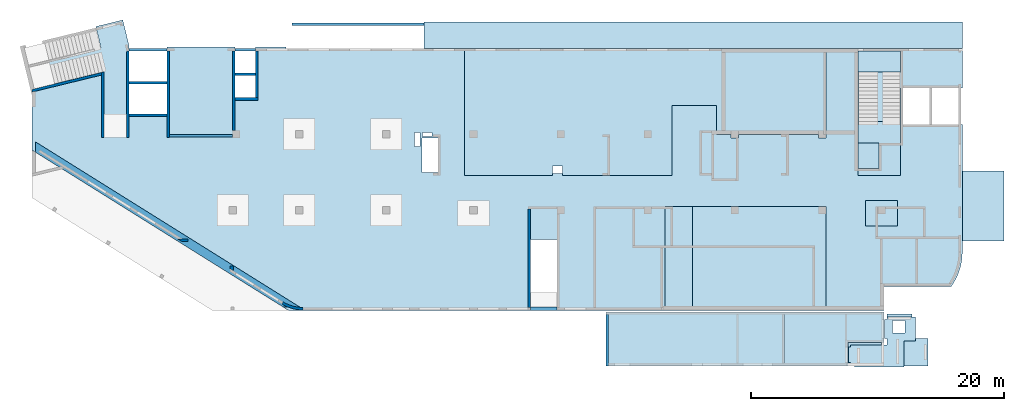
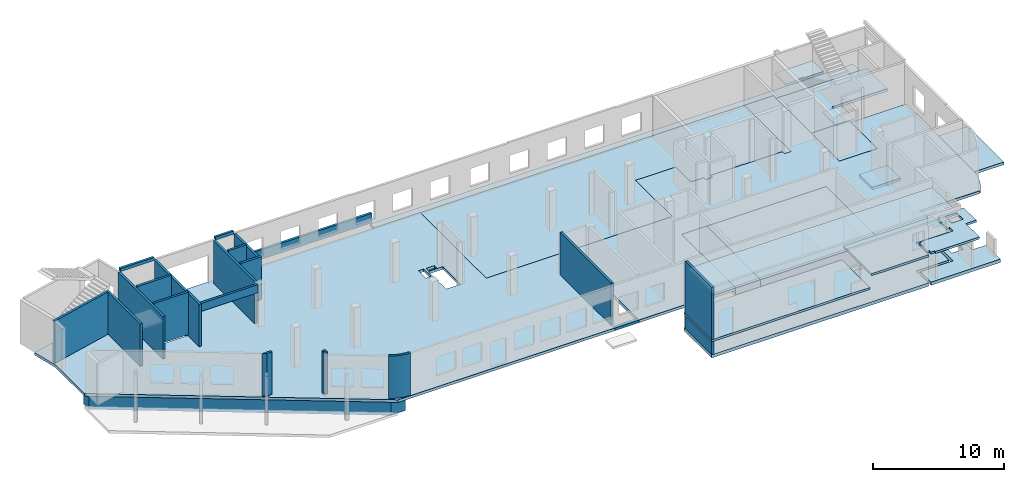
# One storey, part 2 of 8: 21 walls, 17 slabs, 1 opening.
"""IFC4 building model written with IfcOpenShell, lengths in millimetres."""

import ifcopenshell
import ifcopenshell.guid

model = None  # the IFC model being written
_history = None  # IfcOwnerHistory: only IFC2X3 demands one
_inside = {}  # id of a spatial element -> (the spatial element, [elements in it])
_under = {}  # id of a project, library or spatial element -> (it, [spatial elements below it])
_declared = {}  # id of a project -> (the project, [libraries it declares])
_typed = {}  # id of a type object -> (the type object, [elements of that type])
_made_of = {}  # id of a material, layer set ... -> (it, [elements and type objects made of it])


def new_model(schema):
    """Start an empty IFC model of exactly this schema.

    Asked for "IFC4X3", IfcOpenShell would pick the latest addendum, in which some entities
    have other attributes; the version numbers below select the first issue.
    IFC2X3 requires an IfcOwnerHistory on every rooted entity: one is made here for all.
    """
    global model, _history
    if schema == "IFC4X3":
        model = ifcopenshell.file(schema_version=(4, 3, 0, 0))
    else:
        model = ifcopenshell.file(schema=schema)
    _inside.clear()
    _under.clear()
    _declared.clear()
    _typed.clear()
    _made_of.clear()
    _history = None
    if model.schema == "IFC2X3":
        org = make("IfcOrganization", Name="unknown")
        user = make(
            "IfcPersonAndOrganization",
            ThePerson=make("IfcPerson", FamilyName="unknown"),
            TheOrganization=org,
        )
        app = make(
            "IfcApplication",
            ApplicationDeveloper=org,
            Version="unknown",
            ApplicationFullName="unknown",
            ApplicationIdentifier="unknown",
        )
        _history = make(
            "IfcOwnerHistory",
            OwningUser=user,
            OwningApplication=app,
            ChangeAction="ADDED",
            CreationDate=0,
        )
    return model


def make(cls, **values):
    """One entity of the class cls with the attributes given. An attribute that is None is left unset."""
    return model.create_entity(
        cls, **{name: value for name, value in values.items() if value is not None}
    )


def entity(cls, *values):
    """Any entity or typed value of the class cls, its attributes in the order of the schema. None: left unset."""
    e = model.create_entity(cls)
    for i, value in enumerate(values):
        if value is not None:
            e[i] = value
    return e


def rooted(cls, **values):
    """An entity with a GlobalId (a new one), such as an element, a storey or a relation."""
    return make(cls, GlobalId=ifcopenshell.guid.new(), OwnerHistory=_history, **values)


def si_unit(unit_type, name, prefix=None):
    """IfcSIUnit, for example si_unit("LENGTHUNIT", "METRE", prefix="MILLI")."""
    return make("IfcSIUnit", UnitType=unit_type, Prefix=prefix, Name=name)


def converted_unit(unit_type, name, factor, base, dimensions=None, offset=None):
    """IfcConversionBasedUnit, such as the inch: factor (a typed value) times the base unit."""
    return make(
        "IfcConversionBasedUnit"
        if offset is None
        else "IfcConversionBasedUnitWithOffset",
        ConversionOffset=offset,
        Dimensions=None
        if dimensions is None
        else entity("IfcDimensionalExponents", *dimensions),
        UnitType=unit_type,
        Name=name,
        ConversionFactor=make(
            "IfcMeasureWithUnit", ValueComponent=factor, UnitComponent=base
        ),
    )


def derived_unit(unit_type, elements):
    """IfcDerivedUnit: a product of units, each with its exponent."""
    return make(
        "IfcDerivedUnit",
        Elements=[
            make("IfcDerivedUnitElement", Unit=unit, Exponent=power)
            for unit, power in elements
        ],
        UnitType=unit_type,
    )


def assignment(units):
    """IfcUnitAssignment: the units of a project."""
    return None if units is None else make("IfcUnitAssignment", Units=units)


def point(xyz):
    """IfcCartesianPoint."""
    return None if xyz is None else make("IfcCartesianPoint", Coordinates=xyz)


def direction(xyz):
    """IfcDirection."""
    return None if xyz is None else make("IfcDirection", DirectionRatios=xyz)


def frame(location, z_axis=None, x_axis=None):
    """IfcAxis2Placement3D, a coordinate frame: its origin and axes. An axis left out is left unset."""
    return make(
        "IfcAxis2Placement3D",
        Location=point(location),
        Axis=direction(z_axis),
        RefDirection=direction(x_axis),
    )


def origin():
    """The frame at (0, 0, 0) with its axes left unset."""
    return frame((0.0, 0.0, 0.0))


def place(relative_to, where):
    """IfcLocalPlacement: puts the frame where relative to a parent placement (None: the world)."""
    return make(
        "IfcLocalPlacement", PlacementRelTo=relative_to, RelativePlacement=where
    )


def context(
    kind, dimensions, precision=None, world=None, true_north=None, identifier=None
):
    """IfcGeometricRepresentationContext, for example the 3D "Model" context."""
    return make(
        "IfcGeometricRepresentationContext",
        ContextIdentifier=identifier,
        ContextType=kind,
        CoordinateSpaceDimension=dimensions,
        Precision=precision,
        WorldCoordinateSystem=world,
        TrueNorth=true_north,
    )


def subcontext(parent, identifier, kind, view, scale=None):
    """IfcGeometricRepresentationSubContext, for example "Body" below "Model"."""
    return make(
        "IfcGeometricRepresentationSubContext",
        ContextIdentifier=identifier,
        ContextType=kind,
        ParentContext=parent,
        TargetScale=scale,
        TargetView=view,
    )


def project(units=None, contexts=None):
    """IfcProject with its units and contexts."""
    return rooted(
        "IfcProject",
        Name="project",
        RepresentationContexts=contexts,
        UnitsInContext=assignment(units),
    )


def spatial(cls, under=None, at=None, **own):
    """A site, building, storey or space (cls), placed at a placement, below another one or the project."""
    s = rooted(cls, ObjectPlacement=at, **own)
    if under is not None:
        _under.setdefault(under.id(), (under, []))[1].append(s)
    return s


def point_list(points):
    """IfcCartesianPointList2D or 3D."""
    cls = (
        "IfcCartesianPointList2D" if len(points[0]) == 2 else "IfcCartesianPointList3D"
    )
    return make(cls, CoordList=points)


def indexed_curve(points, segments=None, self_intersect=None):
    """IfcIndexedPolyCurve: lines and arcs through numbered points (the first is 1)."""
    return make(
        "IfcIndexedPolyCurve",
        Points=point_list(points),
        Segments=segments,
        SelfIntersect=self_intersect,
    )


def outline(outer, holes=None, kind="AREA"):
    """IfcArbitraryClosedProfileDef: a profile drawn as a closed curve; with holes, ...WithVoids."""
    if holes is None:
        return make("IfcArbitraryClosedProfileDef", ProfileType=kind, OuterCurve=outer)
    return make(
        "IfcArbitraryProfileDefWithVoids",
        ProfileType=kind,
        OuterCurve=outer,
        InnerCurves=holes,
    )


def extrude(swept, where, along, depth):
    """IfcExtrudedAreaSolid: the profile swept, set in the frame where, extruded along a direction by depth."""
    return make(
        "IfcExtrudedAreaSolid",
        SweptArea=swept,
        Position=where,
        ExtrudedDirection=direction(along),
        Depth=depth,
    )


def shape(context_of_items, identifier, shape_type, items):
    """IfcShapeRepresentation: the items that make up one representation, for example the "Body"."""
    return make(
        "IfcShapeRepresentation",
        ContextOfItems=context_of_items,
        RepresentationIdentifier=identifier,
        RepresentationType=shape_type,
        Items=items,
    )


def material(Name=None, Category=None):
    """IfcMaterial."""
    return make("IfcMaterial", Name=Name, Category=Category)


def made_of(thing, what):
    """Note that an element or type object is made of a material, layer set ...; save() writes the relation."""
    if what is not None:
        _made_of.setdefault(what.id(), (what, []))[1].append(thing)
    return thing


def type_object(cls, material=None, **own):
    """A type object (cls), such as IfcWallType, which elements share."""
    return made_of(rooted(cls, **own), material)


def element(
    cls,
    number,
    at=None,
    inside=None,
    cuts=None,
    type_object=None,
    material=None,
    context=None,
    identifier="Body",
    shape_type=None,
    held_by="IfcProductDefinitionShape",
    body=None,
    shapes=None,
    **own,
):
    """One element of the class cls, such as IfcWall. Its Tag is "e" and its number.

    at: its placement. inside: the storey or other place that contains it. cuts: it is an
    opening in that element (IfcRelVoidsElement). A single representation is given by context,
    identifier, shape_type and body (its items); several are given by shapes. held_by: the class
    of the entity that holds the representations. save() writes the other relations.
    """
    e = rooted(cls, Tag="e%d" % number, ObjectPlacement=at, **own)
    if body is not None:
        shapes = [shape(context, identifier, shape_type, body)]
    if shapes is not None:
        e.Representation = make(held_by, Representations=shapes)
    if inside is not None:
        _inside.setdefault(inside.id(), (inside, []))[1].append(e)
    if cuts is not None:
        rooted(
            "IfcRelVoidsElement", RelatingBuildingElement=cuts, RelatedOpeningElement=e
        )
    if type_object is not None:
        _typed.setdefault(type_object.id(), (type_object, []))[1].append(e)
    return made_of(e, material)


def aggregate(whole, parts):
    """IfcRelAggregates: a whole, such as a stair, and the parts it consists of."""
    return rooted("IfcRelAggregates", RelatingObject=whole, RelatedObjects=parts)


def save(model, path):
    """Write the relations noted so far, then the file.

    IfcRelAggregates (storeys below a building ...), IfcRelContainedInSpatialStructure (elements
    in a storey), IfcRelDefinesByType, IfcRelAssociatesMaterial and IfcRelDeclares: one each for
    every whole, place, type object, material and project.
    """
    for whole, parts in _under.values():
        aggregate(whole, parts)
    for where, things in _inside.values():
        rooted(
            "IfcRelContainedInSpatialStructure",
            RelatedElements=things,
            RelatingStructure=where,
        )
    for kind, things in _typed.values():
        rooted("IfcRelDefinesByType", RelatedObjects=things, RelatingType=kind)
    for what, things in _made_of.values():
        rooted("IfcRelAssociatesMaterial", RelatedObjects=things, RelatingMaterial=what)
    for by, libraries in _declared.values():
        rooted("IfcRelDeclares", RelatingContext=by, RelatedDefinitions=libraries)
    model.write(path)


model = new_model("IFC4")

# Units and contexts
model_context = context("Model", 3, precision=0.01, world=origin(), true_north=direction((6.12303176911189e-17, 1.0)))
plan_context = context("Plan", 3, precision=0.01, world=origin(), true_north=direction((6.12303176911189e-17, 1.0)))
body_context = subcontext(model_context, "Body", "Model", "MODEL_VIEW")
ifc_project = project(units=[si_unit("LENGTHUNIT", "METRE", prefix="MILLI"), si_unit("AREAUNIT", "SQUARE_METRE"), si_unit("VOLUMEUNIT", "CUBIC_METRE"), converted_unit("PLANEANGLEUNIT", "DEGREE", entity("IfcRatioMeasure", 0.0174532925199433), si_unit("PLANEANGLEUNIT", "RADIAN"), dimensions=[0, 0, 0, 0, 0, 0, 0]), si_unit("MASSUNIT", "GRAM", prefix="KILO"), derived_unit("MASSDENSITYUNIT", [(si_unit("MASSUNIT", "GRAM", prefix="KILO"), 1), (si_unit("LENGTHUNIT", "METRE"), -3)]), derived_unit("MOMENTOFINERTIAUNIT", [(si_unit("LENGTHUNIT", "METRE"), 4)]), si_unit("TIMEUNIT", "SECOND"), si_unit("FREQUENCYUNIT", "HERTZ"), si_unit("THERMODYNAMICTEMPERATUREUNIT", "DEGREE_CELSIUS"), derived_unit("THERMALTRANSMITTANCEUNIT", [(si_unit("MASSUNIT", "GRAM", prefix="KILO"), 1), (si_unit("THERMODYNAMICTEMPERATUREUNIT", "KELVIN"), -1), (si_unit("TIMEUNIT", "SECOND"), -3)]), derived_unit("VOLUMETRICFLOWRATEUNIT", [(si_unit("LENGTHUNIT", "METRE"), 3), (si_unit("TIMEUNIT", "SECOND"), -1)]), derived_unit("MASSFLOWRATEUNIT", [(si_unit("MASSUNIT", "GRAM", prefix="KILO"), 1), (si_unit("TIMEUNIT", "SECOND"), -1)]), derived_unit("ROTATIONALFREQUENCYUNIT", [(si_unit("TIMEUNIT", "SECOND"), -1)]), si_unit("ELECTRICCURRENTUNIT", "AMPERE"), si_unit("ELECTRICVOLTAGEUNIT", "VOLT"), si_unit("POWERUNIT", "WATT"), si_unit("FORCEUNIT", "NEWTON", prefix="KILO"), si_unit("ILLUMINANCEUNIT", "LUX"), si_unit("LUMINOUSFLUXUNIT", "LUMEN"), si_unit("LUMINOUSINTENSITYUNIT", "CANDELA"), derived_unit("USERDEFINED", [(si_unit("MASSUNIT", "GRAM", prefix="KILO"), -1), (si_unit("LENGTHUNIT", "METRE"), -2), (si_unit("TIMEUNIT", "SECOND"), 3), (si_unit("LUMINOUSFLUXUNIT", "LUMEN"), 1)]), derived_unit("LINEARVELOCITYUNIT", [(si_unit("LENGTHUNIT", "METRE"), 1), (si_unit("TIMEUNIT", "SECOND"), -1)]), si_unit("PRESSUREUNIT", "PASCAL"), derived_unit("USERDEFINED", [(si_unit("LENGTHUNIT", "METRE"), -2), (si_unit("MASSUNIT", "GRAM", prefix="KILO"), 1), (si_unit("TIMEUNIT", "SECOND"), -2)]), derived_unit("LINEARFORCEUNIT", [(si_unit("MASSUNIT", "GRAM", prefix="KILO"), 1), (si_unit("LENGTHUNIT", "METRE"), 1), (si_unit("TIMEUNIT", "SECOND"), -2), (si_unit("LENGTHUNIT", "METRE"), -1)]), derived_unit("PLANARFORCEUNIT", [(si_unit("MASSUNIT", "GRAM", prefix="KILO"), 1), (si_unit("LENGTHUNIT", "METRE"), 1), (si_unit("TIMEUNIT", "SECOND"), -2), (si_unit("LENGTHUNIT", "METRE"), -2)])], contexts=[model_context, plan_context])

# Site, building, storey
site_placement = place(None, origin())
site = spatial("IfcSite", under=ifc_project, at=site_placement, CompositionType="ELEMENT")
building_placement = place(site_placement, origin())
building = spatial("IfcBuilding", under=site, at=building_placement, CompositionType="ELEMENT")
storey_placement = place(building_placement, origin())
storey = spatial("IfcBuildingStorey", under=building, at=storey_placement, CompositionType="ELEMENT", Elevation=0.0)

# Slabs
ifc_material = material()
slab_type_1 = type_object("IfcSlabType", PredefinedType="FLOOR", material=ifc_material)
slab_1_placement = place(storey_placement, origin())
element("IfcSlab", 1, at=slab_1_placement, inside=storey, type_object=slab_type_1, material=ifc_material, PredefinedType="FLOOR", context=body_context, shape_type="SweptSolid", body=[
    extrude(outline(indexed_curve([(-4025.15643417913, -37177.3291465367), (351.455717432071, -37177.3291465367), (13063.9605678396, -16832.6716368716), (13063.9605678396, 2292.67085346331), (7438.9605678395, 2292.67085346332), (7438.9605678395, 4392.67085346331), (13063.9605678396, 4392.67085346332), (13063.9605678396, 12942.6708534633), (4813.96056783958, 12942.6708534633), (4813.9605678396, 25692.6708534633), (13063.9605678396, 25692.6708534633), (13063.9605678396, 30292.6708534633), (11168.9605678397, 30292.6708534633), (11168.9605678397, 35600.554123733), (10925.2178127369, 35765.5271370395), (10671.6270838178, 35914.9204701934), (10409.1828450559, 36048.1482725668), (10138.9142797407, 36164.6880871666), (9861.88125450251, 36264.0828994655), (9579.17016301315, 36345.9429295988), (9291.88966565861, 36409.9471608985), (9001.16634189293, 36455.8445987701), (8708.14027232157, 36483.4552549756), (8413.96056783968, 36492.6708534633), (-1656.03943216033, 36492.6708534633), (-1656.03943216033, 31592.6708534633), (2388.96056783964, 31592.6708534633), (2388.96056783965, 28252.6708534633), (-7686.04007152704, 28252.6708534633), (-7686.04007152704, 25692.6708534633), (-586.039432160554, 25692.6708534633), (-586.039432160553, 25092.6708534633), (-886.03943216039, 25092.6708534633), (-886.039432160402, 18792.6708534633), (-586.039432160566, 18792.6708534633), (-586.039432160567, 18192.6708534633), (-886.039432160399, 18192.6708534633), (-886.039432160403, 17042.6708534633), (-3186.03943216043, 17042.6708534633), (-3186.03943216044, 13492.6708534633), (2388.96056783952, 13492.6708534633), (2388.9605678395, 4857.6708534633), (2228.96056783951, 4857.67085346331), (2228.96056783951, 4027.67085346331), (2388.9605678395, 4027.67085346332), (2388.96056783949, -2907.32914653667), (-7686.04007152708, -2907.32914653666), (-7686.0400715271, -17067.3291465367), (-7786.0400715271, -17067.3291465367), (-7786.0400715271, -19452.3291465367), (-3686.0400715271, -19452.3291465367), (-3686.0400715271, -21077.3291465367), (-7786.03943216063, -21077.3291465367), (-7786.03943216064, -26477.3291465367), (-2386.04007152711, -26477.3291465367), (-2386.04007152711, -29477.3291465367), (-7905.81506587364, -29477.3291465367), (-9940.31254426151, -29973.2594314532), (-9419.29513968276, -32110.6739593644), (-7748.22559967943, -31703.333079421), (-6279.90570125012, -37726.9481351627), (-4025.15643417913, -37177.3291465367)], self_intersect=False), holes=[indexed_curve([(88.9597941956961, -6427.32941509152), (88.9597941956991, -6887.32941509151), (-1051.04020580432, -6887.3294150915), (-1051.04020580432, -6427.32941509151), (88.9597941956961, -6427.32941509152)], self_intersect=False), indexed_curve([(-706.040205804316, -6247.32941509151), (-1026.04020580432, -6247.32941509151), (-1026.04020580432, -5487.32941509151), (-706.040205804318, -5487.32941509151), (-706.040205804316, -6247.32941509151)], self_intersect=False), indexed_curve([(-586.040205804311, -5007.3291465367), (2123.95979419568, -5007.3291465367), (2123.95979419568, -6287.3294150915), (-586.040205804309, -6287.32941509151), (-586.040205804311, -5007.3291465367)], self_intersect=False)]), frame((37177.3294150914, 12813.9597941957, -400.0), z_axis=(0.0, 0.0, 1.0), x_axis=(0.0, -1.0, 0.0)), (0.0, 0.0, 1.0), 250.0),
])
slab_type_2 = type_object("IfcSlabType", PredefinedType="FLOOR", material=ifc_material)
slab_2_placement = place(storey_placement, origin())
element("IfcSlab", 2, at=slab_2_placement, inside=storey, type_object=slab_type_2, material=ifc_material, PredefinedType="FLOOR", context=body_context, shape_type="SweptSolid", body=[
    extrude(outline(indexed_curve([(-1049.99999999993, -21305.0), (1050.00000000006, -21305.0), (1049.99999999993, 21305.0), (-1050.00000000007, 21305.0), (-1049.99999999993, -21305.0)], self_intersect=False)), frame((52365.0002685547, 21549.9998657227, -1350.0), z_axis=(0.0, 0.0, -1.0), x_axis=(0.0, 1.0, 0.0)), (0.0, 0.0, 1.0), 250.0),
])
slab_type_3 = type_object("IfcSlabType", PredefinedType="FLOOR", material=ifc_material)
slab_3_placement = place(storey_placement, origin())
element("IfcSlab", 3, at=slab_3_placement, inside=storey, type_object=slab_type_3, material=ifc_material, PredefinedType="FLOOR", context=body_context, shape_type="SweptSolid", body=[
    extrude(outline(indexed_curve([(-4125.00000000001, -1100.00000000001), (4125.00000000001, -1100.00000000001), (4125.00000000001, 1100.0), (-4125.00000000001, 1100.0), (-4125.00000000001, -1100.00000000001)], self_intersect=False)), frame((51220.0002685546, 3874.99922635607, -150.0), z_axis=(0.0, 0.0, -1.0), x_axis=(0.0, 1.0, 0.0)), (0.0, 0.0, 1.0), 800.0),
])
slab_type_4 = type_object("IfcSlabType", PredefinedType="FLOOR", material=ifc_material)
slab_4_placement = place(storey_placement, origin())
element("IfcSlab", 4, at=slab_4_placement, inside=storey, type_object=slab_type_4, material=ifc_material, PredefinedType="FLOOR", context=body_context, shape_type="SweptSolid", body=[
    extrude(outline(indexed_curve([(-4125.00000000001, -5275.00000000001), (4125.00000000002, -5275.00000000001), (4125.0, 5275.0), (-4125.00000000002, 5275.0), (-4125.00000000001, -5275.00000000001)], self_intersect=False)), frame((57595.0002685547, 3874.99922635605, -150.0), z_axis=(0.0, 0.0, -1.0), x_axis=(0.0, 1.0, 0.0)), (0.0, 0.0, 1.0), 1550.0),
])
slab_type_5 = type_object("IfcSlabType", PredefinedType="FLOOR", material=ifc_material)
slab_5_placement = place(storey_placement, origin())
element("IfcSlab", 5, at=slab_5_placement, inside=storey, type_object=slab_type_5, material=ifc_material, PredefinedType="FLOOR", context=body_context, shape_type="SweptSolid", body=[
    extrude(outline(indexed_curve([(-3212.22229326293, -16716.6666666666), (6862.77834610364, -16716.6666666666), (6862.7783461036, 11883.3333333333), (-237.222293262878, 11883.3333333333), (-237.222293262877, 11283.3333333333), (62.7777067369642, 11283.3333333333), (62.7777067369729, 4983.33333333333), (-237.222293262868, 4983.33333333333), (-237.222293262867, 4383.33333333333), (62.777706736974, 4383.33333333333), (62.7777067369764, 3233.33333333334), (2362.777706737, 3233.33333333334), (2362.777706737, -316.666666666659), (-3212.22229326295, -316.666666666658), (-3212.22229326294, -8951.66666666666), (-2452.22229326295, -8951.66666666666), (-2452.22229326295, -9781.66666666666), (-3212.22229326294, -9781.66666666665), (-3212.22229326293, -16716.6666666666)], self_intersect=False)), frame((50986.6669352213, 13637.2215196191, -150.0), z_axis=(0.0, 0.0, -1.0), x_axis=(0.0, 1.0, 0.0)), (0.0, 0.0, 1.0), 300.0),
])
slab_type_6 = type_object("IfcSlabType", PredefinedType="FLOOR", material=ifc_material)
slab_6_placement = place(storey_placement, origin())
element("IfcSlab", 6, at=slab_6_placement, inside=storey, type_object=slab_type_6, material=ifc_material, PredefinedType="FLOOR", context=body_context, shape_type="SweptSolid", body=[
    extrude(outline(indexed_curve([(-2762.50000000002, -1650.0), (2762.50000000002, -1650.0), (2762.50000000002, 1650.00000000001), (-2762.50000000002, 1650.00000000001), (-2762.50000000002, -1650.0)], self_intersect=False)), frame((75320.0002685547, 8037.49922635593, -1150.0), z_axis=(0.0, 0.0, -1.0), x_axis=(0.0, 1.0, 0.0)), (0.0, 0.0, 1.0), 250.0),
])
slab_type_7 = type_object("IfcSlabType", PredefinedType="FLOOR", material=ifc_material)
slab_7_placement = place(storey_placement, origin())
element("IfcSlab", 7, at=slab_7_placement, inside=storey, type_object=slab_type_7, material=ifc_material, PredefinedType="FLOOR", context=body_context, shape_type="SweptSolid", body=[
    extrude(outline(indexed_curve([(-2803.33354645554, -3859.99999999998), (2966.66709291113, -3859.99999999998), (2966.66709291112, 4380.0), (-163.333546455577, 4379.99999999999), (-163.333546455569, -520.000000000003), (-2803.33354645555, -519.999999999999), (-2803.33354645554, -3859.99999999998)], self_intersect=False)), frame((69290.0002685547, 17533.3327728115, -480.0), z_axis=(0.0, 0.0, -1.0), x_axis=(0.0, 1.0, 0.0)), (0.0, 0.0, 1.0), 250.0),
])
slab_type_8 = type_object("IfcSlabType", PredefinedType="FLOOR", material=ifc_material)
slab_8_placement = place(storey_placement, origin())
element("IfcSlab", 8, at=slab_8_placement, inside=storey, type_object=slab_type_8, material=ifc_material, PredefinedType="FLOOR", context=body_context, shape_type="SweptSolid", body=[
    extrude(outline(indexed_curve([(-2152.5, -1669.99999999999), (2152.5, -1669.99999999999), (2152.5, 1669.99999999998), (-2152.5, 1669.99999999998), (-2152.5, -1669.99999999999)], self_intersect=False)), frame((67100.0002685547, 12577.499226356, -150.0), z_axis=(0.0, 0.0, -1.0), x_axis=(0.0, 1.0, 0.0)), (0.0, 0.0, 1.0), 580.0),
])
slab_type_9 = type_object("IfcSlabType", PredefinedType="FLOOR", material=ifc_material)
slab_9_placement = place(storey_placement, origin())
element("IfcSlab", 9, at=slab_9_placement, inside=storey, type_object=slab_type_9, material=ifc_material, PredefinedType="FLOOR", context=body_context, shape_type="SweptSolid", body=[
    extrude(outline(indexed_curve([(-999.999999999959, -1250.0), (999.99999999996, -1250.0), (999.99999999996, 1250.0), (-999.999999999959, 1250.0), (-999.999999999959, -1250.0)], self_intersect=False)), frame((67270.0002685546, 7449.99922635614, -400.0), z_axis=(0.0, 0.0, -1.0), x_axis=(0.0, 1.0, 0.0)), (0.0, 0.0, 1.0), 250.0),
])
slab_type_10 = type_object("IfcSlabType", PredefinedType="FLOOR", material=ifc_material)
slab_10_placement = place(storey_placement, origin())
element("IfcSlab", 10, at=slab_10_placement, inside=storey, type_object=slab_type_10, material=ifc_material, PredefinedType="FLOOR", context=body_context, shape_type="SweptSolid", body=[
    extrude(outline(indexed_curve([(-1023.11069658518, -824.999999999994), (1023.11069658518, -824.999999999994), (1023.11069658518, 825.000000000003), (-1023.11069658518, 825.000000000003), (-1023.11069658518, -824.999999999994)], self_intersect=False)), frame((66255.0002685547, 12006.8885297708, 2880.0), z_axis=(0.0, 0.0, -1.0), x_axis=(0.0, 1.0, 0.0)), (0.0, 0.0, 1.0), 150.0),
])
slab_type_11 = type_object("IfcSlabType", PredefinedType="FLOOR", material=ifc_material)
slab_11_placement = place(storey_placement, origin())
element("IfcSlab", 11, at=slab_11_placement, inside=storey, type_object=slab_type_11, material=ifc_material, PredefinedType="FLOOR", context=body_context, shape_type="SweptSolid", body=[
    extrude(outline(indexed_curve([(-834.999999999999, -1670.00000000001), (835.000000000001, -1670.00000000001), (835.000000000001, 1670.00000000002), (-834.999999999999, 1670.00000000002), (-834.999999999999, -1670.00000000001)], self_intersect=False)), frame((67100.0002685547, 19464.999226356, 2070.0), z_axis=(0.0, 0.0, -1.0), x_axis=(0.0, 1.0, 0.0)), (0.0, 0.0, 1.0), 200.0),
])
slab_type_12 = type_object("IfcSlabType", PredefinedType="BASESLAB", material=ifc_material)
slab_12_placement = place(storey_placement, origin())
element("IfcSlab", 12, at=slab_12_placement, inside=storey, type_object=slab_type_12, material=ifc_material, PredefinedType="BASESLAB", context=body_context, shape_type="SweptSolid", body=[
    extrude(outline(indexed_curve([(-2033.33335672864, -13709.9988838903), (2216.66664327133, -13709.9988838903), (2216.6666432713, 8289.99776778043), (-183.333286542667, 8289.99776778043), (-183.333286542664, 5420.00111610987), (-2033.33335672866, 5420.00111610987), (-2033.33335672864, -13709.9988838903)], self_intersect=False)), frame((59180.0025007742, -2586.66751861391, -2100.0), z_axis=(0.0, 0.0, -1.0), x_axis=(0.0, 1.0, 0.0)), (0.0, 0.0, 1.0), 300.0),
])
slab_type_13 = type_object("IfcSlabType", PredefinedType="BASESLAB", material=ifc_material)
slab_13_placement = place(storey_placement, origin())
element("IfcSlab", 13, at=slab_13_placement, inside=storey, type_object=slab_type_13, material=ifc_material, PredefinedType="BASESLAB", context=body_context, shape_type="SweptSolid", body=[
    extrude(outline(indexed_curve([(346.250044284976, -3465.00000565502), (1971.25003272099, -3465.00000565502), (1971.25003272101, 2655.00001400014), (-193.750038675896, 2655.00001400014), (-193.750038675899, 1404.99998828339), (-2123.75003833008, 1404.99998828339), (-2123.75003833009, -594.99999662851), (346.250044284985, -594.99999662851), (346.250044284976, -3465.00000565502)], self_intersect=False), holes=[indexed_curve([(-593.75006897793, -165.000012131557), (-1643.75006897793, -165.000012131557), (-1643.75006897793, 884.999987868378), (-593.75006897793, 884.999987868378), (-593.75006897793, -165.000012131557)], self_intersect=False)]), frame((68290.0036290157, -2648.75084262158, -2400.0), z_axis=(0.0, 0.0, 1.0), x_axis=(0.0, -1.0, 0.0)), (0.0, 0.0, 1.0), 300.0),
])
slab_type_14 = type_object("IfcSlabType", PredefinedType="FLOOR", material=ifc_material)
slab_14_placement = place(storey_placement, origin())
element("IfcSlab", 14, at=slab_14_placement, inside=storey, type_object=slab_type_14, material=ifc_material, PredefinedType="FLOOR", context=body_context, shape_type="SweptSolid", body=[
    extrude(outline(indexed_curve([(-2125.00000000001, -6977.50000000006), (2125.00000000001, -6977.50000000006), (2125.00000000001, 6977.50000000006), (-2125.00000000001, 6977.50000000006), (-2125.00000000001, -6977.50000000006)], self_intersect=False)), frame((52447.5036168839, -2495.00087534257, -700.0), z_axis=(0.0, 0.0, -1.0), x_axis=(0.0, 1.0, 0.0)), (0.0, 0.0, 1.0), 200.0),
])
slab_type_15 = type_object("IfcSlabType", PredefinedType="FLOOR", material=ifc_material)
slab_15_placement = place(storey_placement, origin())
element("IfcSlab", 15, at=slab_15_placement, inside=storey, type_object=slab_type_15, material=ifc_material, PredefinedType="FLOOR", context=body_context, shape_type="SweptSolid", body=[
    extrude(outline(indexed_curve([(-2033.33335672867, -4306.66555055693), (2216.66664327135, -4306.66555055693), (2216.66664327134, 3588.33110111375), (-183.333286542677, 3588.33110111375), (-183.333286542674, 718.334449443186), (-2033.33335672867, 718.33444944319), (-2033.33335672867, -4306.66555055693)], self_intersect=False)), frame((63881.6691674409, -2586.66751861391, 530.0), z_axis=(0.0, 0.0, -1.0), x_axis=(0.0, 1.0, 0.0)), (0.0, 0.0, 1.0), 200.0),
])
slab_type_16 = type_object("IfcSlabType", PredefinedType="FLOOR", material=ifc_material)
slab_16_placement = place(storey_placement, origin())
element("IfcSlab", 16, at=slab_16_placement, inside=storey, type_object=slab_type_16, material=ifc_material, PredefinedType="FLOOR", context=body_context, shape_type="SweptSolid", body=[
    extrude(outline(indexed_curve([(2228.33335127655, 305.555637011421), (3128.33332560626, 305.555637011421), (3128.33332560625, 2205.55563701143), (878.333340648085, 2205.55563701143), (878.333340648086, 1990.55550940005), (703.333325144812, 1990.55550940005), (703.333325144817, 490.555510421834), (878.33334064809, 490.555510421834), (878.333340648092, -34.4444462957527), (-1991.66666837842, -34.4444462957521), (-1991.66666837842, -159.444560785931), (-2166.66667485519, -159.444560785931), (-2166.66667485518, -1409.44456078592), (-1991.66666837841, -1409.44456078592), (-1991.66666837841, -1644.44436298856), (-1666.66667171176, -1644.44436298856), (-1666.66667171176, -1744.44436298856), (2228.33335127656, -1744.44436298856), (2228.33335127655, 305.555637011421)], self_intersect=False), holes=[indexed_curve([(2333.32951382663, 1930.55566696699), (2333.32951382663, 930.555666966988), (1333.32951382658, 930.555666966985), (1333.32951382658, 1930.55566696698), (2333.32951382663, 1930.55566696699)], self_intersect=False)]), frame((66816.6702917391, -2960.5564406108, 490.0)), (0.0, 0.0, 1.0), 200.0),
])
slab_type_17 = type_object("IfcSlabType", PredefinedType="FLOOR", material=ifc_material)
slab_17_placement = place(storey_placement, origin())
element("IfcSlab", 17, at=slab_17_placement, inside=storey, type_object=slab_type_17, material=ifc_material, PredefinedType="FLOOR", context=body_context, shape_type="SweptSolid", body=[
    extrude(outline(indexed_curve([(-1925.00000000002, -10799.9983258354), (1925.00000000002, -10799.9983258354), (1925.00000000002, 10799.9983258354), (-1925.00000000002, 10799.9983258354), (-1925.00000000002, -10799.9983258354)], self_intersect=False)), frame((56470.0019427192, -2495.00087534257, 3430.0), z_axis=(0.0, 0.0, -1.0), x_axis=(0.0, 1.0, 0.0)), (0.0, 0.0, 1.0), 200.0),
])

# Walls
wall_type_1 = type_object("IfcWallType", PredefinedType="STANDARD")
wall_1_placement = place(storey_placement, frame((39370.0002685546, 7799.99922635609, 0.0), z_axis=(0.0, 0.0, 1.0), x_axis=(0.0, -1.0, 0.0)))
element("IfcWall", 18, at=wall_1_placement, inside=storey, type_object=wall_type_1, material=ifc_material, PredefinedType="NOTDEFINED", context=body_context, shape_type="SweptSolid", body=[
    extrude(outline(indexed_curve([(7799.9999999999, 100.000000000003), (-1.08967761438837e-13, 100.000000000003), (1.08967761438837e-13, -100.000000000003), (7799.9999999999, -100.000000000003), (7799.9999999999, 100.000000000003)], self_intersect=False)), origin(), (0.0, 0.0, 1.0), 3950.0),
])
wall_2_placement = place(storey_placement, frame((5600.00026855468, 18641.0568697434, -150.0), z_axis=(0.0, 0.0, 1.0), x_axis=(0.0, -1.0, 0.0)))
element("IfcWall", 19, at=wall_2_placement, inside=storey, type_object=wall_type_1, material=ifc_material, PredefinedType="NOTDEFINED", context=body_context, shape_type="SweptSolid", body=[
    extrude(outline(indexed_curve([(5191.05764338694, -99.9999999999995), (5191.05764338694, 100.0), (-2.17498395156585e-13, 100.0), (48.7521159583305, -99.9999999999999), (254.608300734048, -99.9999999999994), (5191.05764338694, -99.9999999999995)], self_intersect=False)), origin(), (0.0, 0.0, 1.0), 3950.0),
])
wall_3_placement = place(storey_placement, frame((5523.68287785372, 18495.1495479709, -150.0), z_axis=(0.0, 0.0, 1.0), x_axis=(-0.971552058141474, -0.236826092990334, 0.0)))
element("IfcWall", 20, at=wall_3_placement, inside=storey, type_object=wall_type_1, material=ifc_material, PredefinedType="NOTDEFINED", context=body_context, shape_type="SweptSolid", body=[
    extrude(outline(indexed_curve([(5661.04508133225, -100.0), (5709.79719729058, 99.9999999999997), (5401.01292012701, 100.0), (48.7521159583298, 99.9999999999999), (2.41107134257845e-13, -100.0), (5458.73710852648, -100.000000000001), (5661.04508133225, -100.0)], self_intersect=False)), origin(), (0.0, 0.0, 1.0), 3950.0),
])
wall_4_placement = place(storey_placement, frame((7600.00026855469, 20297.5240905814, -150.0), z_axis=(0.0, 0.0, 1.0), x_axis=(0.0, -1.0, 0.0)))
element("IfcWall", 21, at=wall_4_placement, inside=storey, type_object=wall_type_1, material=ifc_material, PredefinedType="NOTDEFINED", context=body_context, shape_type="SweptSolid", body=[
    extrude(outline(indexed_curve([(6847.52486422499, -100.0), (6847.52486422499, 99.9999999999998), (5097.52422485856, 99.9999999999998), (-1.86299721169617e-13, 100.0), (24.0243306802184, -100.0), (6847.52486422499, -100.0)], self_intersect=False)), origin(), (0.0, 0.0, 1.0), 3950.0),
])
wall_5_placement = place(storey_placement, frame((10800.0002685547, 20299.9992263564, -150.0), z_axis=(0.0, 0.0, 1.0), x_axis=(0.0, -1.0, 0.0)))
element("IfcWall", 22, at=wall_5_placement, inside=storey, type_object=wall_type_1, material=ifc_material, PredefinedType="NOTDEFINED", context=body_context, shape_type="SweptSolid", body=[
    extrude(outline(indexed_curve([(6849.99999999998, 99.9999999999997), (-1.68937704985105e-13, 99.9999999999989), (1.68937704985105e-13, -99.9999999999989), (6849.99999999998, -99.9999999999982), (6849.99999999998, 99.9999999999997)], self_intersect=False)), origin(), (0.0, 0.0, 1.0), 3950.0),
])
for number, where, z_axis, x_axis in (
    (23, (10700.0002685547, 17799.9992263564, 0.0), (0.0, 0.0, 1.0), (-1.0, 0.0, 0.0)),
    (24, (10700.0002685547, 15199.9992263564, 0.0), (0.0, 0.0, 1.0), (-1.0, 0.0, 0.0)),
):
    element("IfcWall", number, at=place(storey_placement, frame(where, z_axis=z_axis, x_axis=x_axis)), inside=storey, type_object=wall_type_1, material=ifc_material, PredefinedType="NOTDEFINED", context=body_context, shape_type="SweptSolid", body=[
        extrude(outline(indexed_curve([(3000.0, 99.9999999999989), (-2.88764567812902e-13, 99.9999999999989), (2.88764567812902e-13, -99.9999999999989), (3000.00000000001, -99.9999999999989), (3000.0, 99.9999999999989)], self_intersect=False)), origin(), (0.0, 0.0, 1.0), 3950.0),
    ])
wall_6_placement = place(storey_placement, frame((16000.0002685547, 20299.9992263564, -150.0), z_axis=(0.0, 0.0, 1.0), x_axis=(0.0, -1.0, 0.0)))
element("IfcWall", 25, at=wall_6_placement, inside=storey, type_object=wall_type_1, material=ifc_material, PredefinedType="NOTDEFINED", context=body_context, shape_type="SweptSolid", body=[
    extrude(outline(indexed_curve([(6300.00000000003, 99.9999999999989), (-1.37506937053763e-13, 99.9999999999989), (1.37506937053763e-13, -99.9999999999989), (6300.00000000003, -99.9999999999989), (6300.00000000003, 99.9999999999989)], self_intersect=False)), origin(), (0.0, 0.0, 1.0), 3950.0),
])
wall_7_placement = place(storey_placement, frame((17825.0002685547, 20299.9992263564, -150.0), z_axis=(0.0, 0.0, 1.0), x_axis=(0.0, -1.0, 0.0)))
element("IfcWall", 26, at=wall_7_placement, inside=storey, type_object=wall_type_1, material=ifc_material, PredefinedType="NOTDEFINED", context=body_context, shape_type="SweptSolid", body=[
    extrude(outline(indexed_curve([(3700.00000000023, 99.9999999999984), (4.24739052372736e-13, 99.9999999999989), (-4.24739052372736e-13, -99.9999999999989), (3700.00000000023, -99.9999999999995), (3700.00000000023, 99.9999999999984)], self_intersect=False)), origin(), (0.0, 0.0, 1.0), 3950.0),
])
wall_8_placement = place(storey_placement, frame((17725.0002685547, 18449.9992263563, 0.0), z_axis=(0.0, 0.0, 1.0), x_axis=(-1.0, 0.0, 0.0)))
element("IfcWall", 27, at=wall_8_placement, inside=storey, type_object=wall_type_1, material=ifc_material, PredefinedType="NOTDEFINED", context=body_context, shape_type="SweptSolid", body=[
    extrude(outline(indexed_curve([(1624.99999999999, 99.9999999999989), (-2.66551908750371e-13, 99.9999999999989), (2.66551908750371e-13, -99.9999999999989), (1624.99999999999, -99.9999999999989), (1624.99999999999, 99.9999999999989)], self_intersect=False)), origin(), (0.0, 0.0, 1.0), 3950.0),
])
wall_9_placement = place(storey_placement, frame((17925.0002685547, 16499.9992263561, 0.0), z_axis=(0.0, 0.0, 1.0), x_axis=(-1.0, 0.0, 0.0)))
element("IfcWall", 28, at=wall_9_placement, inside=storey, type_object=wall_type_1, material=ifc_material, PredefinedType="NOTDEFINED", context=body_context, shape_type="SweptSolid", body=[
    extrude(outline(indexed_curve([(1825.00000000001, 99.9999999999995), (-2.66551908750371e-13, 99.9999999999989), (2.66551908750371e-13, -99.9999999999989), (1825.00000000001, -99.9999999999984), (1825.00000000001, 99.9999999999995)], self_intersect=False)), origin(), (0.0, 0.0, 1.0), 3950.0),
])
wall_10_placement = place(storey_placement, frame((15900.0002685547, 13599.9992263563, 3050.0), z_axis=(0.0, 0.0, 1.0), x_axis=(-1.0, 0.0, 0.0)))
element("IfcWall", 29, at=wall_10_placement, inside=storey, type_object=wall_type_1, material=ifc_material, PredefinedType="NOTDEFINED", context=body_context, shape_type="SweptSolid", body=[
    extrude(outline(indexed_curve([(4999.99999999999, 99.9999999999989), (-3.03202796203547e-13, 99.9999999999989), (3.03202796203547e-13, -99.9999999999989), (4999.99999999999, -99.9999999999989), (4999.99999999999, 99.9999999999989)], self_intersect=False)), origin(), (0.0, 0.0, 1.0), 750.000000000001),
])
wall_11_placement = place(storey_placement, frame((21465.0002685546, -100.000773643695, -150.0)))
element("IfcWall", 30, at=wall_11_placement, inside=storey, type_object=wall_type_1, material=ifc_material, PredefinedType="NOTDEFINED", context=body_context, shape_type="SweptSolid", body=[
    extrude(outline(indexed_curve([(-1669.7311591292, 370.165232796515), (-1503.53564298382, 275.220261635061), (-1331.96118607575, 190.381571616725), (-1155.62145828086, 115.952573238706), (-975.147407258616, 52.1995580227518), (-791.184711518204, -0.649408149811444), (-604.391528471895, -42.4052699025555), (-415.436139881236, -72.9186585351565), (-224.989102437801, -92.0805293177081), (-125.0800800656, -97.5545301950318), (-25.0252657996871, -99.9011362110873), (-12.5071092046703, -99.9755580659273), (-2.16573425859679e-11, -100.0), (2.16573425859679e-11, 100.0), (-164.508224209949, 104.513888503692), (-328.521400565239, 118.041970555148), (-491.545970938373, 140.54353665167), (-653.091352173336, 171.950873752911), (-812.671412377343, 212.169469046957), (-969.805933817615, 261.078294363853), (-1124.02205802091, 318.530170380714), (-1274.85570872713, 384.352209522427), (-1421.85298841503, 458.346336225146), (-1564.57154419737, 540.289882996962), (-1669.7311591292, 370.165232796515)], self_intersect=False)), origin(), (0.0, 0.0, 1.0), 3950.0),
])
wall_12_placement = place(storey_placement, frame((12375.0002685547, 5299.99922635636, -150.0), z_axis=(0.0, 0.0, 1.0), x_axis=(-1.0, 0.0, 0.0)))
element("IfcWall", 31, at=wall_12_placement, inside=storey, type_object=wall_type_1, material=ifc_material, PredefinedType="NOTDEFINED", context=body_context, shape_type="SweptSolid", body=[
    extrude(outline(indexed_curve([(789.343084396992, -100.0), (469.26993203138, 99.9999999999996), (-3.81254187175444e-13, 100.0), (3.81254187175444e-13, -100.0), (411.921804041392, -99.9999999999995), (789.343084396992, -100.0)], self_intersect=False)), origin(), (0.0, 0.0, 1.0), 3950.0),
])
wall_13_placement = place(storey_placement, frame((20590.0002685547, 22399.9992263561, -1075.0)))
element("IfcWall", 32, at=wall_13_placement, inside=storey, type_object=wall_type_1, material=ifc_material, PredefinedType="NOTDEFINED", context=body_context, shape_type="SweptSolid", body=[
    extrude(outline(indexed_curve([(10470.0, 99.9999999999994), (-3.35772753270816e-13, 99.9999999999989), (3.35772753270816e-13, -99.9999999999989), (10470.0, -99.9999999999984), (10470.0, 99.9999999999994)], self_intersect=False)), origin(), (0.0, 0.0, 1.0), 900.0),
])
wall_14_placement = place(storey_placement, frame((16100.0002685547, 20399.9998657227, 3750.0)))
element("IfcWall", 33, at=wall_14_placement, inside=storey, type_object=wall_type_1, material=ifc_material, PredefinedType="NOTDEFINED", context=body_context, shape_type="SweptSolid", body=[
    extrude(outline(indexed_curve([(1624.99999999998, 99.9999999999989), (-2.66551908750373e-13, 99.9999999999989), (2.66551908750373e-13, -99.9999999999989), (1624.99999999998, -99.9999999999989), (1624.99999999998, 99.9999999999989)], self_intersect=False)), origin(), (0.0, 0.0, 1.0), 299.999999999999),
])
wall_15_placement = place(storey_placement, frame((7700.0002685547, 20399.9998657227, 3750.0)))
element("IfcWall", 34, at=wall_15_placement, inside=storey, type_object=wall_type_1, material=ifc_material, PredefinedType="NOTDEFINED", context=body_context, shape_type="SweptSolid", body=[
    extrude(outline(indexed_curve([(2999.99999999997, 99.9999999999989), (-2.88764567812905e-13, 99.9999999999989), (2.88764567812905e-13, -99.9999999999989), (2999.99999999997, -99.9999999999989), (2999.99999999997, 99.9999999999989)], self_intersect=False)), origin(), (0.0, 0.0, 1.0), 299.999999999999),
])

# Wall, opening
wall_16_placement = place(storey_placement, frame((45570.0036168839, -4620.00087534259, -2100.0), z_axis=(0.0, 0.0, 1.0), x_axis=(0.0, 1.0, 0.0)))
wall_16 = element("IfcWall", 35, at=wall_16_placement, inside=storey, type_object=wall_type_1, material=ifc_material, PredefinedType="NOTDEFINED", context=body_context, shape_type="SweptSolid", body=[
    extrude(outline(indexed_curve([(4050.00000000003, 100.000000000003), (0.0, 100.000000000003), (0.0, -100.000000000003), (4050.00000000003, -100.000000000003), (4050.00000000003, 100.000000000003)], self_intersect=False)), origin(), (0.0, 0.0, 1.0), 6280.0),
])
opening_placement = place(storey_placement, frame((45570.0036168839, -4620.00087534259, -2100.0), z_axis=(0.0, 0.0, 1.0), x_axis=(0.0, 1.0, 0.0)))
element("IfcOpeningElement", 36, at=opening_placement, cuts=wall_16, PredefinedType="OPENING", context=body_context, shape_type="SweptSolid", body=[
    extrude(outline(indexed_curve([(-2025.00000000002, -100.000000000003), (2025.00000000002, -100.000000000003), (2025.00000000002, 99.9999999999946), (-2025.00000000002, 99.9999999999946), (-2025.00000000002, -100.000000000003)], self_intersect=False)), frame((2025.0, 0.0, 1200.0)), (0.0, 0.0, 1.0), 200.0),
])

# Walls
wall_type_2 = type_object("IfcWallType", PredefinedType="STANDARD")
wall_17_placement = place(storey_placement, frame((39470.0002685546, -100.000773643819, -400.0)))
element("IfcWall", 37, at=wall_17_placement, inside=storey, type_object=wall_type_2, material=ifc_material, PredefinedType="NOTDEFINED", context=body_context, shape_type="SweptSolid", body=[
    extrude(outline(indexed_curve([(2100.00000000002, 150.0), (-1.04267903610388e-12, 150.0), (1.04267903610388e-12, -150.0), (2100.00000000002, -150.0), (2100.00000000002, 150.0)], self_intersect=False)), origin(), (0.0, 0.0, 1.0), 250.0),
])
wall_type_3 = type_object("IfcWallType", PredefinedType="STANDARD")
wall_18_placement = place(storey_placement, frame((21000.0533916715, -246.819233965844, -1620.0), z_axis=(0.0, 0.0, 1.0), x_axis=(-0.848052743777574, 0.529911826412026, 0.0)))
element("IfcWall", 38, at=wall_18_placement, inside=storey, type_object=wall_type_3, material=ifc_material, PredefinedType="NOTDEFINED", context=body_context, shape_type="SweptSolid", body=[
    extrude(outline(indexed_curve([(24627.6218261242, -350.000000000003), (24190.2218162662, 350.000000000001), (1120.25603327965, 350.000000000001), (-1.35358391162299e-13, -350.0), (24627.6218261242, -350.000000000003)], self_intersect=False)), origin(), (0.0, 0.0, 1.0), 1220.0),
])
wall_type_4 = type_object("IfcWallType", PredefinedType="STANDARD")
wall_19_placement = place(storey_placement, frame((15815.0002685546, 3269.99922635634, 0.0), z_axis=(0.0, 0.0, 1.0), x_axis=(0.0, -1.0, 0.0)))
element("IfcWall", 39, at=wall_19_placement, inside=storey, type_object=wall_type_4, material=ifc_material, PredefinedType="NOTDEFINED", context=body_context, shape_type="SweptSolid", body=[
    extrude(outline(indexed_curve([(192.545191041583, -135.0), (361.256623415384, 135.0), (0.0, 135.0), (0.0, -135.0), (192.545191041583, -135.0)], self_intersect=False)), origin(), (0.0, 0.0, 1.0), 3950.0),
])

save(model, "model.ifc")
